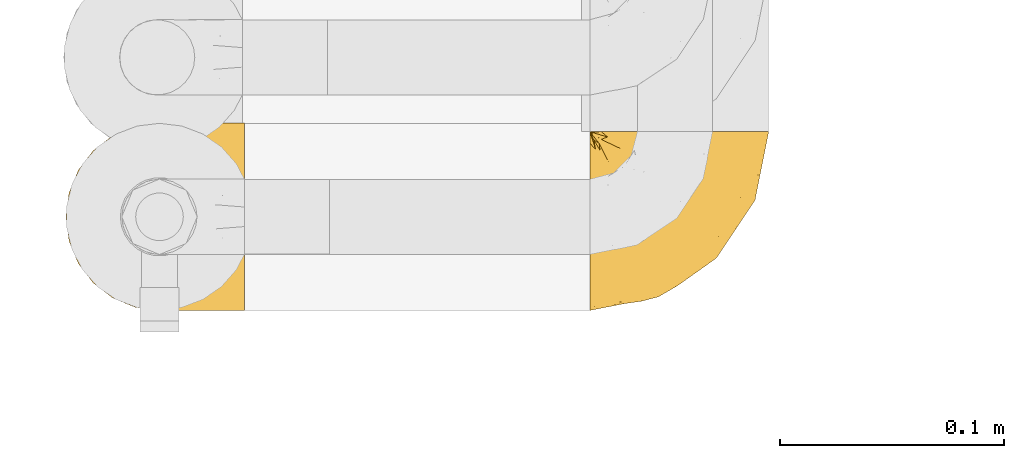
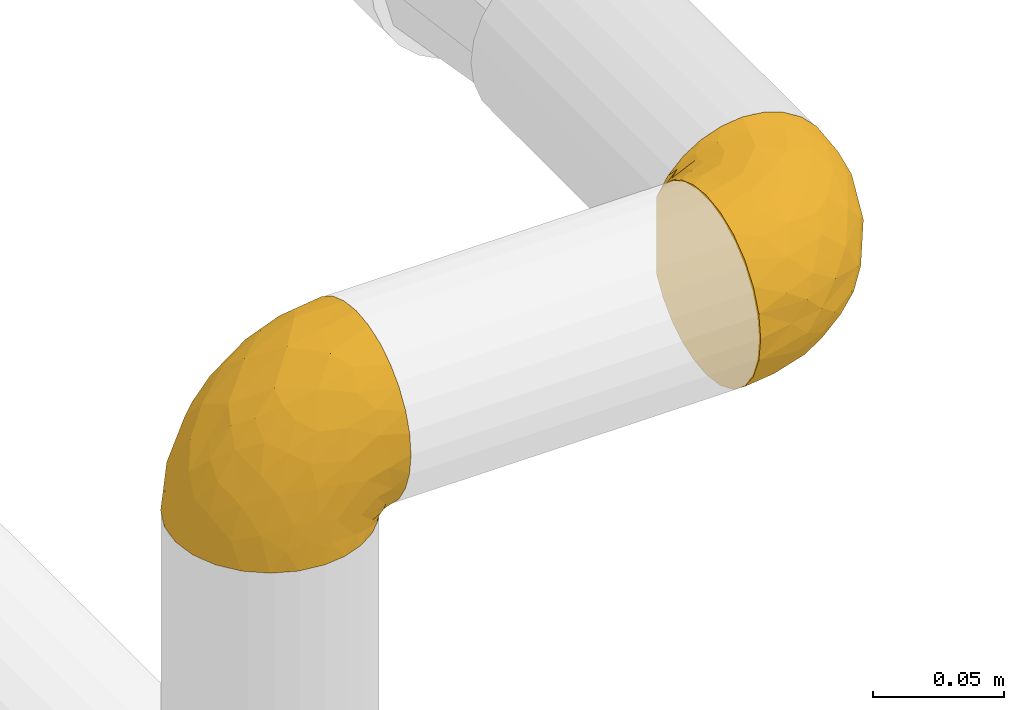
# One storey, part 123 of 827: 2 coverings.
"""IFC2X3 building model written with IfcOpenShell, lengths in millimetres."""

from ifc_helpers import new_model, entity, si_unit, converted_unit, derived_unit, direction, frame, origin, place, context, subcontext, project, spatial, faceted_brep, element, save


model = new_model("IFC2X3")

# Units and contexts
model_context = context("Model", 3, precision=0.01, world=origin(), true_north=direction((6.12303176911189e-17, 1.0)))
body_context = subcontext(model_context, "Body", "Model", "MODEL_VIEW")
ifc_project = project(units=[si_unit("LENGTHUNIT", "METRE", prefix="MILLI"), si_unit("AREAUNIT", "SQUARE_METRE"), si_unit("VOLUMEUNIT", "CUBIC_METRE"), converted_unit("PLANEANGLEUNIT", "DEGREE", entity("IfcRatioMeasure", 0.0174532925199433), si_unit("PLANEANGLEUNIT", "RADIAN"), dimensions=[0, 0, 0, 0, 0, 0, 0]), si_unit("MASSUNIT", "GRAM", prefix="KILO"), derived_unit("MASSDENSITYUNIT", [(si_unit("MASSUNIT", "GRAM", prefix="KILO"), 1), (si_unit("LENGTHUNIT", "METRE"), -3)]), derived_unit("MOMENTOFINERTIAUNIT", [(si_unit("LENGTHUNIT", "METRE"), 4)]), si_unit("TIMEUNIT", "SECOND"), si_unit("FREQUENCYUNIT", "HERTZ"), si_unit("THERMODYNAMICTEMPERATUREUNIT", "DEGREE_CELSIUS"), derived_unit("THERMALTRANSMITTANCEUNIT", [(si_unit("MASSUNIT", "GRAM", prefix="KILO"), 1), (si_unit("THERMODYNAMICTEMPERATUREUNIT", "KELVIN"), -1), (si_unit("TIMEUNIT", "SECOND"), -3)]), derived_unit("VOLUMETRICFLOWRATEUNIT", [(si_unit("LENGTHUNIT", "METRE"), 3), (si_unit("TIMEUNIT", "SECOND"), -1)]), derived_unit("MASSFLOWRATEUNIT", [(si_unit("MASSUNIT", "GRAM", prefix="KILO"), 1), (si_unit("TIMEUNIT", "SECOND"), -1)]), derived_unit("ROTATIONALFREQUENCYUNIT", [(si_unit("TIMEUNIT", "SECOND"), -1)]), si_unit("ELECTRICCURRENTUNIT", "AMPERE"), si_unit("ELECTRICVOLTAGEUNIT", "VOLT"), si_unit("POWERUNIT", "WATT"), si_unit("FORCEUNIT", "NEWTON", prefix="KILO"), si_unit("ILLUMINANCEUNIT", "LUX"), si_unit("LUMINOUSFLUXUNIT", "LUMEN"), si_unit("LUMINOUSINTENSITYUNIT", "CANDELA"), derived_unit("USERDEFINED", [(si_unit("MASSUNIT", "GRAM", prefix="KILO"), -1), (si_unit("LENGTHUNIT", "METRE"), -2), (si_unit("TIMEUNIT", "SECOND"), 3), (si_unit("LUMINOUSFLUXUNIT", "LUMEN"), 1)]), derived_unit("LINEARVELOCITYUNIT", [(si_unit("LENGTHUNIT", "METRE"), 1), (si_unit("TIMEUNIT", "SECOND"), -1)]), si_unit("PRESSUREUNIT", "PASCAL"), derived_unit("USERDEFINED", [(si_unit("LENGTHUNIT", "METRE"), -2), (si_unit("MASSUNIT", "GRAM", prefix="KILO"), 1), (si_unit("TIMEUNIT", "SECOND"), -2)]), derived_unit("LINEARFORCEUNIT", [(si_unit("MASSUNIT", "GRAM", prefix="KILO"), 1), (si_unit("LENGTHUNIT", "METRE"), 1), (si_unit("TIMEUNIT", "SECOND"), -2), (si_unit("LENGTHUNIT", "METRE"), -1)]), derived_unit("PLANARFORCEUNIT", [(si_unit("MASSUNIT", "GRAM", prefix="KILO"), 1), (si_unit("LENGTHUNIT", "METRE"), 1), (si_unit("TIMEUNIT", "SECOND"), -2), (si_unit("LENGTHUNIT", "METRE"), -2)])], contexts=[model_context])

# Site, building, storey
site_placement = place(None, origin())
site = spatial("IfcSite", under=ifc_project, at=site_placement, CompositionType="ELEMENT")
building_placement = place(site_placement, origin())
building = spatial("IfcBuilding", under=site, at=building_placement, CompositionType="ELEMENT")
storey_placement = place(building_placement, frame((0.0, 0.0, 28200.0)))
storey = spatial("IfcBuildingStorey", under=building, at=storey_placement, Name="08", CompositionType="ELEMENT", Elevation=28200.0)

# Coverings
covering_1_placement = place(storey_placement, frame((11731.77, 16451.2, 2230.69)))
element("IfcCovering", 1, at=covering_1_placement, inside=storey, Name=":ADSK_", ObjectType=":ADSK_", PredefinedType="INSULATION", context=body_context, shape_type="Brep", body=[
    faceted_brep([(81.45, 81.15, 57.76), (81.45, 76.16, 65.69), (81.45, 69.53, 72.32), (81.45, 61.6, 77.3), (81.45, 52.75, 80.4), (81.45, 43.45, 81.45), (81.45, 34.13, 80.39), (81.45, 25.28, 77.3), (81.45, 17.35, 72.31), (81.45, 10.72, 65.68), (81.45, 5.74, 57.75), (81.45, 2.64, 48.9), (81.45, 1.6, 39.6), (81.45, 2.66, 30.22), (81.45, 5.79, 21.33), (81.45, 10.83, 13.37), (81.45, 17.53, 6.73), (81.45, 25.53, 1.77), (81.45, 26.45, 1.77), (81.45, 27.37, 1.77), (81.45, 28.17, 1.77), (81.45, 29.49, 1.77), (81.45, 30.81, 1.77), (81.45, 32.13, 1.77), (81.45, 33.45, 1.77), (81.45, 34.78, 1.77), (81.45, 36.1, 1.77), (81.45, 37.42, 1.77), (81.45, 38.74, 1.77), (81.45, 40.06, 1.77), (81.45, 41.38, 1.77), (81.45, 42.7, 1.77), (81.45, 44.02, 1.77), (81.45, 45.34, 1.77), (81.45, 46.66, 1.77), (81.45, 47.58, 1.77), (81.45, 48.5, 1.77), (81.45, 49.41, 1.77), (81.45, 50.33, 1.77), (81.45, 51.25, 1.77), (81.45, 52.17, 1.77), (81.45, 53.09, 1.77), (81.45, 54.01, 1.77), (81.45, 54.93, 1.77), (81.45, 55.85, 1.77), (81.45, 56.76, 1.77), (81.45, 57.68, 1.77), (81.45, 58.6, 1.77), (81.45, 59.52, 1.77), (81.45, 60.44, 1.77), (81.45, 61.36, 1.77), (81.45, 69.37, 6.74), (81.45, 76.07, 13.38), (81.45, 81.11, 21.35), (81.45, 84.24, 30.24), (81.45, 85.3, 39.6), (81.45, 84.24, 48.91), (76.3, 17.52, 1.6), (69.67, 10.83, 1.6), (61.7, 5.79, 1.6), (52.81, 2.66, 1.6), (43.45, 1.6, 1.6), (32.61, 3.02, 1.6), (22.52, 7.2, 1.6), (13.85, 13.85, 1.6), (7.2, 22.52, 1.6), (3.02, 32.61, 1.6), (1.6, 43.45, 1.6), (3.02, 54.28, 1.6), (7.2, 64.37, 1.6), (13.85, 73.04, 1.6), (22.52, 79.69, 1.6), (32.61, 83.87, 1.6), (43.45, 85.3, 1.6), (52.81, 84.23, 1.6), (61.7, 81.1, 1.6), (69.67, 76.06, 1.6), (76.3, 69.37, 1.6), (81.27, 61.36, 1.6), (81.27, 60.44, 1.6), (81.27, 59.12, 1.6), (81.27, 58.0, 1.6), (81.27, 56.88, 1.6), (81.27, 55.76, 1.6), (81.27, 54.64, 1.6), (81.27, 53.52, 1.6), (81.27, 52.4, 1.6), (81.27, 51.28, 1.6), (81.27, 50.16, 1.6), (81.27, 49.04, 1.6), (81.27, 47.92, 1.6), (81.27, 46.8, 1.6), (81.27, 45.68, 1.6), (81.27, 44.56, 1.6), (81.27, 43.45, 1.6), (81.27, 42.12, 1.6), (81.27, 40.8, 1.6), (81.27, 39.48, 1.6), (81.27, 38.16, 1.6), (81.27, 36.84, 1.6), (81.27, 35.52, 1.6), (81.27, 34.2, 1.6), (81.27, 32.88, 1.6), (81.27, 31.96, 1.6), (81.27, 31.05, 1.6), (81.27, 30.13, 1.6), (81.27, 29.21, 1.6), (81.27, 28.29, 1.6), (81.27, 27.37, 1.6), (81.27, 26.45, 1.6), (81.27, 25.53, 1.6), (81.31, 54.08, 1.71), (81.33, 55.16, 1.73), (81.31, 36.18, 1.71), (81.32, 35.13, 1.72), (81.31, 44.01, 1.71), (81.32, 45.08, 1.72), (81.32, 61.36, 1.72), (81.32, 59.98, 1.72), (81.32, 46.18, 1.72), (81.32, 26.74, 1.72), (81.32, 47.36, 1.72), (81.32, 29.67, 1.72), (81.3, 28.72, 1.7), (81.32, 39.77, 1.72), (81.33, 52.96, 1.73), (81.31, 51.84, 1.72), (81.33, 40.8, 1.73), (81.32, 41.87, 1.73), (81.32, 42.94, 1.72), (81.32, 27.77, 1.72), (81.31, 48.4, 1.71), (81.32, 37.21, 1.72), (81.31, 33.54, 1.71), (81.32, 32.49, 1.72), (81.32, 30.69, 1.72), (81.32, 50.69, 1.72), (81.33, 49.6, 1.73), (81.32, 56.32, 1.72), (81.31, 57.44, 1.71), (81.33, 58.88, 1.73), (81.32, 25.53, 1.72), (81.36, 61.36, 1.74), (81.4, 61.36, 1.75), (81.4, 25.53, 1.75), (81.36, 25.53, 1.74), (81.29, 61.36, 1.64), (81.3, 61.36, 1.68), (81.3, 25.53, 1.68), (81.35, 31.59, 1.74), (81.31, 38.71, 1.71), (58.5, 3.97, 8.98), (71.95, 1.6, 37.05), (74.57, 3.97, 24.69), (73.93, 8.09, 15.28), (78.18, 8.09, 16.86), (78.04, 16.43, 6.58), (76.23, 15.73, 5.71), (45.99, 1.6, 11.1), (74.01, 10.79, 10.79), (73.57, 13.99, 4.13), (66.66, 8.08, 6.62), (79.09, 14.0, 9.52), (73.14, 12.83, 6.14), (81.29, 25.53, 1.64), (60.34, 3.18, 17.79), (48.54, 1.6, 20.6), (45.36, 1.6, 8.73), (67.22, 3.28, 23.66), (62.45, 1.6, 34.5), (68.67, 6.28, 15.32), (55.49, 1.6, 27.55), (77.84, 19.06, 3.31), (68.16, 8.08, 9.81), (74.31, 1.6, 37.68), (38.78, 32.11, 67.23), (62.1, 29.62, 76.64), (50.89, 43.45, 75.37), (36.91, 2.45, 14.58), (40.37, 2.5, 23.71), (27.86, 9.73, 34.34), (15.77, 17.97, 29.1), (20.13, 10.24, 18.02), (31.54, 4.78, 22.27), (28.25, 4.78, 10.97), (57.26, 8.01, 56.79), (69.99, 8.01, 60.76), (64.58, 13.85, 67.04), (50.64, 2.42, 36.11), (51.97, 21.17, 68.85), (5.72, 35.73, 24.58), (7.42, 27.43, 21.54), (66.14, 43.45, 78.4), (11.35, 17.97, 14.11), (21.64, 35.71, 53.42), (28.57, 29.47, 58.19), (55.38, 3.41, 44.49), (68.51, 3.94, 51.77), (67.48, 21.17, 73.69), (40.78, 7.92, 45.89), (41.53, 4.25, 35.97), (46.11, 11.75, 56.55), (40.32, 18.31, 60.03), (38.36, 24.94, 63.64), (11.84, 28.78, 34.98), (12.56, 35.82, 40.58), (7.67, 43.45, 32.15), (19.39, 28.38, 47.26), (24.98, 43.45, 58.06), (37.94, 43.45, 66.71), (4.64, 43.45, 16.9), (28.09, 21.21, 52.08), (23.73, 16.48, 41.21), (34.03, 13.85, 49.76), (16.33, 43.45, 45.11), (29.29, 82.11, 15.65), (5.77, 51.41, 24.57), (21.44, 57.45, 50.54), (38.8, 54.78, 67.25), (64.58, 73.03, 67.06), (67.49, 65.7, 73.7), (22.9, 76.65, 26.13), (12.54, 68.92, 19.54), (20.04, 68.01, 38.96), (57.26, 78.88, 56.8), (69.99, 78.88, 60.77), (68.51, 82.94, 51.78), (34.54, 64.44, 59.09), (38.81, 84.49, 19.25), (48.54, 85.3, 20.6), (45.99, 85.3, 11.1), (74.31, 85.3, 37.68), (5.36, 57.84, 15.21), (18.96, 76.65, 12.76), (12.79, 51.19, 40.93), (62.11, 57.26, 76.65), (33.14, 78.14, 39.5), (33.44, 82.35, 25.01), (51.98, 65.7, 68.86), (43.42, 84.61, 26.7), (48.62, 84.36, 34.95), (62.45, 85.3, 34.5), (55.49, 85.3, 27.55), (49.68, 73.03, 61.27), (55.37, 83.48, 44.5), (71.95, 85.3, 37.05), (36.37, 84.54, 10.25), (34.04, 73.03, 49.78), (44.1, 79.54, 47.51), (9.99, 59.46, 29.38), (26.41, 73.5, 40.01), (39.19, 82.57, 33.36), (58.5, 82.92, 8.98), (67.22, 83.62, 23.67), (74.57, 82.92, 24.71), (73.92, 78.81, 15.29), (73.57, 72.9, 4.13), (73.14, 74.06, 6.14), (66.19, 78.81, 4.96), (68.16, 78.81, 9.81), (77.84, 67.83, 3.31), (76.23, 71.15, 5.7), (79.08, 72.91, 9.53), (78.04, 70.47, 6.59), (77.18, 78.81, 16.63), (68.66, 80.62, 15.34), (74.0, 76.11, 10.8), (60.34, 83.71, 17.79)], [[[0, 1, 2, 3, 4, 5, 6, 7, 8, 9, 10, 11, 12, 13, 14, 15, 16, 17, 18, 19, 20, 21, 22, 23, 24, 25, 26, 27, 28, 29, 30, 31, 32, 33, 34, 35, 36, 37, 38, 39, 40, 41, 42, 43, 44, 45, 46, 47, 48, 49, 50, 51, 52, 53, 54, 55, 56]], [[57, 58, 59, 60, 61, 62, 63, 64, 65, 66, 67, 68, 69, 70, 71, 72, 73, 74, 75, 76, 77, 78, 79, 80, 81, 82, 83, 84, 85, 86, 87, 88, 89, 90, 91, 92, 93, 94, 95, 96, 97, 98, 99, 100, 101, 102, 103, 104, 105, 106, 107, 108, 109, 110]], [[111, 84, 112]], [[113, 26, 114]], [[114, 101, 100]], [[115, 93, 116]], [[79, 117, 118]], [[33, 116, 119]], [[117, 49, 118]], [[19, 18, 120]], [[119, 121, 34]], [[122, 21, 123]], [[97, 96, 124]], [[86, 125, 126]], [[116, 92, 119]], [[127, 96, 128]], [[32, 129, 115]], [[19, 120, 130]], [[121, 90, 131]], [[94, 115, 129]], [[115, 116, 32]], [[118, 49, 48]], [[113, 99, 132]], [[133, 114, 25]], [[24, 134, 133]], [[135, 22, 122]], [[136, 137, 88]], [[84, 83, 112]], [[138, 82, 139]], [[130, 20, 19]], [[118, 48, 140]], [[81, 140, 139]], [[123, 21, 20]], [[141, 120, 18]], [[139, 82, 81]], [[130, 107, 123]], [[49, 117, 142, 143, 50]], [[18, 17, 144, 145, 141]], [[79, 78, 146, 147, 117]], [[109, 141, 148]], [[102, 133, 134]], [[105, 135, 122]], [[118, 80, 79]], [[80, 118, 140]], [[120, 109, 108]], [[47, 46, 140, 48]], [[81, 80, 140]], [[44, 112, 138]], [[93, 115, 94]], [[46, 139, 140]], [[46, 45, 139]], [[139, 45, 138]], [[138, 112, 83]], [[85, 84, 111]], [[112, 43, 111]], [[83, 82, 138]], [[106, 122, 123]], [[105, 122, 106]], [[21, 122, 22]], [[124, 29, 28]], [[33, 32, 116]], [[128, 129, 31]], [[32, 31, 129]], [[34, 33, 119]], [[116, 93, 92]], [[129, 95, 94]], [[95, 129, 128]], [[41, 40, 125, 42]], [[119, 91, 121]], [[36, 35, 131, 37]], [[137, 131, 89]], [[121, 131, 35]], [[90, 121, 91]], [[119, 92, 91]], [[136, 126, 39]], [[125, 86, 85]], [[42, 125, 111]], [[85, 111, 125]], [[149, 23, 22]], [[130, 108, 107]], [[130, 123, 20]], [[107, 106, 123]], [[137, 37, 131]], [[136, 38, 137]], [[89, 88, 137]], [[131, 90, 89]], [[124, 150, 97]], [[40, 39, 126]], [[87, 126, 136]], [[86, 126, 87]], [[136, 88, 87]], [[40, 126, 125]], [[39, 38, 136]], [[95, 128, 96]], [[30, 128, 31]], [[29, 124, 127]], [[127, 128, 30]], [[150, 124, 28]], [[127, 30, 29]], [[127, 124, 96]], [[150, 98, 97]], [[45, 44, 138]], [[26, 113, 132]], [[113, 100, 99]], [[132, 150, 27]], [[27, 26, 132]], [[26, 25, 114]], [[100, 113, 114]], [[101, 133, 102]], [[133, 101, 114]], [[28, 27, 150]], [[132, 99, 98]], [[23, 134, 24]], [[25, 24, 133]], [[134, 23, 149]], [[135, 104, 149]], [[149, 104, 103]], [[103, 102, 134]], [[130, 120, 108]], [[109, 120, 141]], [[42, 111, 43]], [[112, 44, 43]], [[104, 135, 105]], [[134, 149, 103]], [[135, 149, 22]], [[35, 34, 121]], [[137, 38, 37]], [[98, 150, 132]], [[59, 151, 60]], [[13, 152, 153]], [[154, 155, 153]], [[156, 157, 141]], [[158, 60, 151]], [[159, 156, 154]], [[160, 161, 58]], [[58, 161, 59]], [[144, 16, 162]], [[58, 57, 160]], [[161, 160, 163]], [[156, 162, 154]], [[162, 16, 15]], [[57, 164, 160]], [[151, 165, 166]], [[156, 144, 162]], [[60, 158, 167, 61]], [[155, 14, 153]], [[162, 155, 154]], [[154, 153, 168]], [[168, 153, 169]], [[154, 170, 159]], [[57, 110, 164]], [[144, 17, 16]], [[155, 15, 14]], [[171, 165, 168]], [[157, 163, 172]], [[14, 13, 153]], [[156, 141, 145, 144]], [[173, 163, 157]], [[173, 159, 170]], [[171, 166, 165]], [[168, 165, 170]], [[168, 169, 171]], [[151, 173, 165]], [[170, 154, 168]], [[165, 173, 170]], [[159, 173, 157]], [[172, 164, 148]], [[148, 141, 157]], [[157, 156, 159]], [[151, 166, 158]], [[173, 151, 161]], [[59, 161, 151]], [[13, 12, 174, 152]], [[152, 169, 153]], [[15, 155, 162]], [[161, 163, 173]], [[172, 163, 160]], [[164, 172, 160]], [[157, 172, 148]], [[175, 176, 177]], [[178, 166, 179]], [[180, 181, 182]], [[183, 184, 178]], [[185, 186, 187]], [[171, 188, 179]], [[174, 12, 11]], [[189, 176, 175]], [[190, 66, 191]], [[176, 6, 192]], [[193, 65, 64]], [[63, 184, 182]], [[63, 182, 64]], [[65, 193, 191]], [[184, 63, 62]], [[175, 194, 195]], [[196, 169, 197]], [[174, 11, 197]], [[8, 7, 198]], [[187, 9, 8]], [[197, 169, 152, 174]], [[197, 11, 10]], [[186, 197, 10]], [[199, 180, 200]], [[197, 185, 196]], [[201, 189, 202]], [[201, 187, 189]], [[195, 203, 175]], [[191, 204, 190]], [[176, 7, 6]], [[177, 176, 192]], [[189, 198, 176]], [[65, 191, 66]], [[198, 187, 8]], [[205, 206, 190]], [[9, 186, 10]], [[181, 207, 204]], [[208, 175, 177, 209]], [[66, 190, 210]], [[211, 212, 213]], [[190, 204, 205]], [[180, 182, 183]], [[193, 182, 181]], [[62, 61, 167]], [[196, 185, 199]], [[196, 200, 188]], [[6, 5, 192]], [[176, 198, 7]], [[187, 198, 189]], [[187, 186, 9]], [[197, 186, 185]], [[200, 180, 183]], [[180, 213, 212]], [[179, 183, 178]], [[185, 201, 199]], [[210, 190, 206]], [[210, 67, 66]], [[205, 204, 207]], [[194, 205, 207]], [[194, 214, 205]], [[195, 194, 207]], [[208, 194, 175]], [[207, 211, 195]], [[202, 203, 211]], [[212, 207, 181]], [[202, 211, 213]], [[201, 202, 213]], [[189, 175, 203]], [[199, 201, 213]], [[187, 201, 185]], [[180, 199, 213]], [[196, 199, 200]], [[211, 203, 195]], [[189, 203, 202]], [[207, 212, 211]], [[180, 212, 181]], [[214, 194, 208]], [[214, 206, 205]], [[196, 188, 169]], [[181, 204, 191]], [[182, 193, 64]], [[191, 193, 181]], [[178, 62, 167]], [[182, 184, 183]], [[62, 178, 184]], [[178, 167, 158, 166]], [[171, 179, 166]], [[200, 183, 179]], [[179, 188, 200]], [[169, 188, 171]], [[71, 215, 72]], [[206, 216, 210]], [[217, 208, 218]], [[216, 68, 210]], [[219, 220, 2]], [[221, 222, 223]], [[224, 225, 226]], [[227, 223, 217]], [[228, 229, 230]], [[56, 231, 226]], [[232, 222, 69]], [[56, 55, 231]], [[70, 233, 71]], [[71, 233, 215]], [[0, 56, 226]], [[208, 217, 234]], [[218, 177, 235]], [[221, 236, 237]], [[238, 220, 219]], [[1, 219, 2]], [[68, 216, 232]], [[235, 3, 220]], [[235, 192, 4]], [[1, 0, 225]], [[228, 239, 229]], [[240, 241, 242]], [[243, 238, 219]], [[224, 226, 244]], [[226, 241, 244]], [[3, 235, 4]], [[69, 222, 70]], [[225, 219, 1]], [[218, 235, 238]], [[243, 219, 224]], [[218, 227, 217]], [[3, 2, 220]], [[218, 208, 209, 177]], [[226, 231, 245, 241]], [[215, 228, 246]], [[247, 248, 236]], [[248, 224, 244]], [[223, 222, 249]], [[233, 222, 221]], [[242, 239, 240]], [[248, 247, 243]], [[217, 223, 249]], [[250, 247, 236]], [[216, 234, 249]], [[218, 238, 227]], [[192, 235, 177]], [[192, 5, 4]], [[72, 246, 73]], [[235, 220, 238]], [[226, 225, 0]], [[219, 225, 224]], [[240, 248, 244]], [[239, 242, 229]], [[236, 248, 251]], [[68, 67, 210]], [[234, 216, 206]], [[216, 249, 232]], [[234, 206, 214, 208]], [[249, 234, 217]], [[222, 232, 249]], [[69, 68, 232]], [[246, 228, 230]], [[237, 228, 215]], [[243, 227, 238]], [[223, 227, 247]], [[73, 246, 230]], [[215, 246, 72]], [[248, 243, 224]], [[227, 243, 247]], [[237, 236, 251]], [[250, 221, 223]], [[222, 233, 70]], [[215, 233, 221]], [[221, 237, 215]], [[239, 237, 251]], [[237, 239, 228]], [[239, 251, 240]], [[248, 240, 251]], [[241, 240, 244]], [[221, 250, 236]], [[223, 247, 250]], [[74, 230, 252]], [[253, 254, 255]], [[146, 77, 256]], [[257, 258, 259]], [[260, 256, 257]], [[260, 261, 147]], [[75, 74, 252]], [[51, 143, 262]], [[263, 143, 142, 117]], [[256, 77, 76]], [[252, 258, 75]], [[253, 241, 254]], [[254, 245, 54]], [[258, 256, 76]], [[53, 52, 264]], [[255, 265, 253]], [[254, 264, 255]], [[255, 264, 262]], [[75, 258, 76]], [[265, 255, 266]], [[255, 262, 263]], [[51, 50, 143]], [[54, 245, 231, 55]], [[51, 262, 52]], [[253, 267, 242]], [[254, 54, 53]], [[266, 259, 265]], [[146, 78, 77]], [[263, 117, 261]], [[146, 256, 260]], [[257, 259, 261]], [[267, 253, 265]], [[229, 267, 252]], [[242, 267, 229]], [[242, 241, 253]], [[252, 267, 259]], [[255, 263, 266]], [[259, 267, 265]], [[261, 117, 147]], [[263, 261, 266]], [[259, 266, 261]], [[230, 74, 73]], [[230, 229, 252]], [[259, 258, 252]], [[254, 241, 245]], [[53, 264, 254]], [[52, 262, 264]], [[143, 263, 262]], [[258, 257, 256]], [[261, 260, 257]], [[146, 260, 147]], [[109, 148, 164]], [[109, 164, 110]]]),
])
covering_2_placement = place(storey_placement, frame((11965.87, 16451.2, 2226.84)))
element("IfcCovering", 2, at=covering_2_placement, inside=storey, Name=":ADSK_", ObjectType=":ADSK_", PredefinedType="INSULATION", context=body_context, shape_type="Brep", body=[
    faceted_brep([(57.76, 81.45, 81.15), (65.69, 81.45, 76.16), (72.32, 81.45, 69.53), (77.3, 81.45, 61.6), (80.4, 81.45, 52.75), (81.45, 81.45, 43.45), (80.39, 81.45, 34.13), (77.3, 81.45, 25.28), (72.31, 81.45, 17.35), (65.68, 81.45, 10.72), (57.75, 81.45, 5.74), (48.9, 81.45, 2.64), (39.6, 81.45, 1.6), (30.22, 81.45, 2.66), (21.33, 81.45, 5.79), (13.37, 81.45, 10.83), (6.73, 81.45, 17.53), (1.77, 81.45, 25.53), (1.77, 81.45, 26.45), (1.77, 81.45, 27.37), (1.77, 81.45, 28.17), (1.77, 81.45, 29.49), (1.77, 81.45, 30.81), (1.77, 81.45, 32.13), (1.77, 81.45, 33.45), (1.77, 81.45, 34.78), (1.77, 81.45, 36.1), (1.77, 81.45, 37.42), (1.77, 81.45, 38.74), (1.77, 81.45, 40.06), (1.77, 81.45, 41.38), (1.77, 81.45, 42.7), (1.77, 81.45, 44.02), (1.77, 81.45, 45.34), (1.77, 81.45, 46.66), (1.77, 81.45, 47.58), (1.77, 81.45, 48.5), (1.77, 81.45, 49.41), (1.77, 81.45, 50.33), (1.77, 81.45, 51.25), (1.77, 81.45, 52.17), (1.77, 81.45, 53.09), (1.77, 81.45, 54.01), (1.77, 81.45, 54.93), (1.77, 81.45, 55.85), (1.77, 81.45, 56.76), (1.77, 81.45, 57.68), (1.77, 81.45, 58.6), (1.77, 81.45, 59.52), (1.77, 81.45, 60.44), (1.77, 81.45, 61.36), (6.74, 81.45, 69.37), (13.38, 81.45, 76.07), (21.35, 81.45, 81.11), (30.24, 81.45, 84.24), (39.6, 81.45, 85.3), (48.91, 81.45, 84.24), (1.6, 76.3, 17.52), (1.6, 69.67, 10.83), (1.6, 61.7, 5.79), (1.6, 52.81, 2.66), (1.6, 43.45, 1.6), (1.6, 32.61, 3.02), (1.6, 22.52, 7.2), (1.6, 13.85, 13.85), (1.6, 7.2, 22.52), (1.6, 3.02, 32.61), (1.6, 1.6, 43.45), (1.6, 3.02, 54.28), (1.6, 7.2, 64.37), (1.6, 13.85, 73.04), (1.6, 22.52, 79.69), (1.6, 32.61, 83.87), (1.6, 43.45, 85.3), (1.6, 52.81, 84.23), (1.6, 61.7, 81.1), (1.6, 69.67, 76.06), (1.6, 76.3, 69.37), (1.6, 81.27, 61.36), (1.6, 81.27, 60.44), (1.6, 81.27, 59.12), (1.6, 81.27, 58.0), (1.6, 81.27, 56.88), (1.6, 81.27, 55.76), (1.6, 81.27, 54.64), (1.6, 81.27, 53.52), (1.6, 81.27, 52.4), (1.6, 81.27, 51.28), (1.6, 81.27, 50.16), (1.6, 81.27, 49.04), (1.6, 81.27, 47.92), (1.6, 81.27, 46.8), (1.6, 81.27, 45.68), (1.6, 81.27, 44.56), (1.6, 81.27, 43.45), (1.6, 81.27, 42.12), (1.6, 81.27, 40.8), (1.6, 81.27, 39.48), (1.6, 81.27, 38.16), (1.6, 81.27, 36.84), (1.6, 81.27, 35.52), (1.6, 81.27, 34.2), (1.6, 81.27, 32.88), (1.6, 81.27, 31.96), (1.6, 81.27, 31.05), (1.6, 81.27, 30.13), (1.6, 81.27, 29.21), (1.6, 81.27, 28.29), (1.6, 81.27, 27.37), (1.6, 81.27, 26.45), (1.6, 81.27, 25.53), (1.71, 81.31, 54.08), (1.73, 81.33, 55.16), (1.71, 81.31, 36.18), (1.72, 81.32, 35.13), (1.71, 81.31, 44.01), (1.72, 81.32, 45.08), (1.72, 81.32, 61.36), (1.72, 81.32, 59.98), (1.72, 81.32, 46.18), (1.72, 81.32, 26.74), (1.72, 81.32, 47.36), (1.72, 81.32, 29.67), (1.7, 81.3, 28.72), (1.72, 81.32, 39.77), (1.73, 81.33, 52.96), (1.72, 81.31, 51.84), (1.73, 81.33, 40.8), (1.73, 81.32, 41.87), (1.72, 81.32, 42.94), (1.72, 81.32, 27.77), (1.71, 81.31, 48.4), (1.72, 81.32, 37.21), (1.71, 81.31, 33.54), (1.72, 81.32, 32.49), (1.72, 81.32, 30.69), (1.72, 81.32, 50.69), (1.73, 81.33, 49.6), (1.72, 81.32, 56.32), (1.71, 81.31, 57.44), (1.73, 81.33, 58.88), (1.72, 81.32, 25.53), (1.74, 81.36, 61.36), (1.75, 81.4, 61.36), (1.75, 81.4, 25.53), (1.74, 81.36, 25.53), (1.64, 81.29, 61.36), (1.68, 81.3, 61.36), (1.68, 81.3, 25.53), (1.64, 81.29, 25.53), (1.74, 81.35, 31.59), (1.71, 81.31, 38.71), (8.98, 58.5, 3.97), (37.05, 71.95, 1.6), (24.69, 74.57, 3.97), (15.28, 73.93, 8.09), (16.86, 78.18, 8.09), (6.58, 78.04, 16.43), (5.71, 76.23, 15.73), (11.1, 45.99, 1.6), (10.79, 74.01, 10.79), (4.13, 73.57, 13.99), (6.62, 66.66, 8.08), (9.52, 79.09, 14.0), (6.14, 73.14, 12.83), (17.79, 60.34, 3.18), (20.6, 48.54, 1.6), (8.73, 45.36, 1.6), (23.66, 67.22, 3.28), (34.5, 62.45, 1.6), (15.32, 68.67, 6.28), (27.55, 55.49, 1.6), (3.31, 77.84, 19.06), (9.81, 68.16, 8.08), (37.68, 74.31, 1.6), (67.23, 38.78, 32.11), (76.64, 62.1, 29.62), (75.37, 50.89, 43.45), (14.58, 36.91, 2.45), (23.71, 40.37, 2.5), (34.34, 27.86, 9.73), (29.1, 15.77, 17.97), (18.02, 20.13, 10.24), (22.27, 31.54, 4.78), (10.97, 28.25, 4.78), (56.79, 57.26, 8.01), (60.76, 69.99, 8.01), (67.04, 64.58, 13.85), (36.11, 50.64, 2.42), (68.85, 51.97, 21.17), (24.58, 5.72, 35.73), (21.54, 7.42, 27.43), (78.4, 66.14, 43.45), (14.11, 11.35, 17.97), (53.42, 21.64, 35.71), (58.19, 28.57, 29.47), (44.49, 55.38, 3.41), (51.77, 68.51, 3.94), (73.69, 67.48, 21.17), (45.89, 40.78, 7.92), (35.97, 41.53, 4.25), (56.55, 46.11, 11.75), (60.03, 40.32, 18.31), (63.64, 38.36, 24.94), (34.98, 11.84, 28.78), (40.58, 12.56, 35.82), (32.15, 7.67, 43.45), (47.26, 19.39, 28.38), (58.06, 24.98, 43.45), (66.71, 37.94, 43.45), (16.9, 4.64, 43.45), (52.08, 28.09, 21.21), (41.21, 23.73, 16.48), (49.76, 34.03, 13.85), (45.11, 16.33, 43.45), (15.65, 29.29, 82.11), (24.57, 5.77, 51.41), (50.54, 21.44, 57.45), (67.25, 38.8, 54.78), (67.06, 64.58, 73.03), (73.7, 67.49, 65.7), (26.13, 22.9, 76.65), (19.54, 12.54, 68.92), (38.96, 20.04, 68.01), (56.8, 57.26, 78.88), (60.77, 69.99, 78.88), (51.78, 68.51, 82.94), (59.09, 34.54, 64.44), (19.25, 38.81, 84.49), (20.6, 48.54, 85.3), (11.1, 45.99, 85.3), (37.68, 74.31, 85.3), (15.21, 5.36, 57.84), (12.76, 18.96, 76.65), (40.93, 12.79, 51.19), (76.65, 62.11, 57.26), (39.5, 33.14, 78.14), (25.01, 33.44, 82.35), (68.86, 51.98, 65.7), (26.7, 43.42, 84.61), (34.95, 48.62, 84.36), (34.5, 62.45, 85.3), (27.55, 55.49, 85.3), (61.27, 49.68, 73.03), (44.5, 55.37, 83.48), (37.05, 71.95, 85.3), (10.25, 36.37, 84.54), (49.78, 34.04, 73.03), (47.51, 44.1, 79.54), (29.38, 9.99, 59.46), (40.01, 26.41, 73.5), (33.36, 39.19, 82.57), (8.98, 58.5, 82.92), (23.67, 67.22, 83.62), (24.71, 74.57, 82.92), (15.29, 73.92, 78.81), (4.13, 73.57, 72.9), (6.14, 73.14, 74.06), (4.96, 66.19, 78.81), (9.81, 68.16, 78.81), (3.31, 77.84, 67.83), (5.7, 76.23, 71.15), (9.53, 79.08, 72.91), (6.59, 78.04, 70.47), (16.63, 77.18, 78.81), (15.34, 68.66, 80.62), (10.8, 74.0, 76.11), (17.79, 60.34, 83.71)], [[[0, 1, 2, 3, 4, 5, 6, 7, 8, 9, 10, 11, 12, 13, 14, 15, 16, 17, 18, 19, 20, 21, 22, 23, 24, 25, 26, 27, 28, 29, 30, 31, 32, 33, 34, 35, 36, 37, 38, 39, 40, 41, 42, 43, 44, 45, 46, 47, 48, 49, 50, 51, 52, 53, 54, 55, 56]], [[57, 58, 59, 60, 61, 62, 63, 64, 65, 66, 67, 68, 69, 70, 71, 72, 73, 74, 75, 76, 77, 78, 79, 80, 81, 82, 83, 84, 85, 86, 87, 88, 89, 90, 91, 92, 93, 94, 95, 96, 97, 98, 99, 100, 101, 102, 103, 104, 105, 106, 107, 108, 109, 110]], [[111, 84, 112]], [[113, 26, 114]], [[114, 101, 100]], [[115, 93, 116]], [[79, 117, 118]], [[33, 116, 119]], [[117, 49, 118]], [[19, 18, 120]], [[119, 121, 34]], [[122, 21, 123]], [[97, 96, 124]], [[86, 125, 126]], [[116, 92, 119]], [[127, 96, 128]], [[32, 129, 115]], [[19, 120, 130]], [[121, 90, 131]], [[94, 115, 129]], [[115, 116, 32]], [[118, 49, 48]], [[113, 99, 132]], [[133, 114, 25]], [[24, 134, 133]], [[135, 22, 122]], [[136, 137, 88]], [[84, 83, 112]], [[138, 82, 139]], [[130, 20, 19]], [[118, 48, 140]], [[81, 140, 139]], [[123, 21, 20]], [[141, 120, 18]], [[139, 82, 81]], [[130, 107, 123]], [[49, 117, 142, 143, 50]], [[18, 17, 144, 145, 141]], [[79, 78, 146, 147, 117]], [[109, 141, 148, 149, 110]], [[102, 133, 134]], [[105, 135, 122]], [[118, 80, 79]], [[80, 118, 140]], [[120, 109, 108]], [[47, 46, 140, 48]], [[81, 80, 140]], [[44, 112, 138]], [[93, 115, 94]], [[46, 139, 140]], [[46, 45, 139]], [[139, 45, 138]], [[138, 112, 83]], [[85, 84, 111]], [[112, 43, 111]], [[83, 82, 138]], [[106, 122, 123]], [[105, 122, 106]], [[21, 122, 22]], [[124, 29, 28]], [[33, 32, 116]], [[128, 129, 31]], [[32, 31, 129]], [[34, 33, 119]], [[116, 93, 92]], [[129, 95, 94]], [[95, 129, 128]], [[41, 40, 125, 42]], [[119, 91, 121]], [[36, 35, 131, 37]], [[137, 131, 89]], [[121, 131, 35]], [[90, 121, 91]], [[119, 92, 91]], [[136, 126, 39]], [[125, 86, 85]], [[42, 125, 111]], [[85, 111, 125]], [[150, 23, 22]], [[130, 108, 107]], [[130, 123, 20]], [[107, 106, 123]], [[137, 37, 131]], [[136, 38, 137]], [[89, 88, 137]], [[131, 90, 89]], [[124, 151, 97]], [[40, 39, 126]], [[87, 126, 136]], [[86, 126, 87]], [[136, 88, 87]], [[40, 126, 125]], [[39, 38, 136]], [[95, 128, 96]], [[30, 128, 31]], [[29, 124, 127]], [[127, 128, 30]], [[151, 124, 28]], [[127, 30, 29]], [[127, 124, 96]], [[151, 98, 97]], [[45, 44, 138]], [[26, 113, 132]], [[113, 100, 99]], [[132, 151, 27]], [[27, 26, 132]], [[26, 25, 114]], [[100, 113, 114]], [[101, 133, 102]], [[133, 101, 114]], [[28, 27, 151]], [[132, 99, 98]], [[23, 134, 24]], [[25, 24, 133]], [[134, 23, 150]], [[135, 104, 150]], [[150, 104, 103]], [[103, 102, 134]], [[130, 120, 108]], [[109, 120, 141]], [[42, 111, 43]], [[112, 44, 43]], [[104, 135, 105]], [[134, 150, 103]], [[135, 150, 22]], [[35, 34, 121]], [[137, 38, 37]], [[98, 151, 132]], [[59, 152, 60]], [[13, 153, 154]], [[155, 156, 154]], [[157, 158, 141]], [[159, 60, 152]], [[160, 157, 155]], [[161, 162, 58]], [[58, 162, 59]], [[144, 16, 163]], [[58, 57, 161]], [[162, 161, 164]], [[157, 163, 155]], [[163, 16, 15]], [[57, 149, 161]], [[152, 165, 166]], [[157, 144, 163]], [[60, 159, 167, 61]], [[156, 14, 154]], [[163, 156, 155]], [[155, 154, 168]], [[168, 154, 169]], [[155, 170, 160]], [[57, 110, 149]], [[144, 17, 16]], [[156, 15, 14]], [[171, 165, 168]], [[158, 164, 172]], [[14, 13, 154]], [[157, 141, 145, 144]], [[173, 164, 158]], [[173, 160, 170]], [[171, 166, 165]], [[168, 165, 170]], [[168, 169, 171]], [[152, 173, 165]], [[170, 155, 168]], [[165, 173, 170]], [[160, 173, 158]], [[172, 149, 148]], [[148, 141, 158]], [[158, 157, 160]], [[152, 166, 159]], [[173, 152, 162]], [[59, 162, 152]], [[13, 12, 174, 153]], [[153, 169, 154]], [[15, 156, 163]], [[162, 164, 173]], [[172, 164, 161]], [[149, 172, 161]], [[158, 172, 148]], [[175, 176, 177]], [[178, 166, 179]], [[180, 181, 182]], [[183, 184, 178]], [[185, 186, 187]], [[171, 188, 179]], [[174, 12, 11]], [[189, 176, 175]], [[190, 66, 191]], [[176, 6, 192]], [[193, 65, 64]], [[63, 184, 182]], [[63, 182, 64]], [[65, 193, 191]], [[184, 63, 62]], [[175, 194, 195]], [[196, 169, 197]], [[174, 11, 197]], [[8, 7, 198]], [[187, 9, 8]], [[197, 169, 153, 174]], [[197, 11, 10]], [[186, 197, 10]], [[199, 180, 200]], [[197, 185, 196]], [[201, 189, 202]], [[201, 187, 189]], [[195, 203, 175]], [[191, 204, 190]], [[176, 7, 6]], [[177, 176, 192]], [[189, 198, 176]], [[65, 191, 66]], [[198, 187, 8]], [[205, 206, 190]], [[9, 186, 10]], [[181, 207, 204]], [[208, 175, 177, 209]], [[66, 190, 210]], [[211, 212, 213]], [[190, 204, 205]], [[180, 182, 183]], [[193, 182, 181]], [[62, 61, 167]], [[196, 185, 199]], [[196, 200, 188]], [[6, 5, 192]], [[176, 198, 7]], [[187, 198, 189]], [[187, 186, 9]], [[197, 186, 185]], [[200, 180, 183]], [[180, 213, 212]], [[179, 183, 178]], [[185, 201, 199]], [[210, 190, 206]], [[210, 67, 66]], [[205, 204, 207]], [[194, 205, 207]], [[194, 214, 205]], [[195, 194, 207]], [[208, 194, 175]], [[207, 211, 195]], [[202, 203, 211]], [[212, 207, 181]], [[202, 211, 213]], [[201, 202, 213]], [[189, 175, 203]], [[199, 201, 213]], [[187, 201, 185]], [[180, 199, 213]], [[196, 199, 200]], [[211, 203, 195]], [[189, 203, 202]], [[207, 212, 211]], [[180, 212, 181]], [[214, 194, 208]], [[214, 206, 205]], [[196, 188, 169]], [[181, 204, 191]], [[182, 193, 64]], [[191, 193, 181]], [[178, 62, 167]], [[182, 184, 183]], [[62, 178, 184]], [[178, 167, 159, 166]], [[171, 179, 166]], [[200, 183, 179]], [[179, 188, 200]], [[169, 188, 171]], [[71, 215, 72]], [[206, 216, 210]], [[217, 208, 218]], [[216, 68, 210]], [[219, 220, 2]], [[221, 222, 223]], [[224, 225, 226]], [[227, 223, 217]], [[228, 229, 230]], [[56, 231, 226]], [[232, 222, 69]], [[56, 55, 231]], [[70, 233, 71]], [[71, 233, 215]], [[0, 56, 226]], [[208, 217, 234]], [[218, 177, 235]], [[221, 236, 237]], [[238, 220, 219]], [[1, 219, 2]], [[68, 216, 232]], [[235, 3, 220]], [[235, 192, 4]], [[1, 0, 225]], [[228, 239, 229]], [[240, 241, 242]], [[243, 238, 219]], [[224, 226, 244]], [[226, 241, 244]], [[3, 235, 4]], [[69, 222, 70]], [[225, 219, 1]], [[218, 235, 238]], [[243, 219, 224]], [[218, 227, 217]], [[3, 2, 220]], [[218, 208, 209, 177]], [[226, 231, 245, 241]], [[215, 228, 246]], [[247, 248, 236]], [[248, 224, 244]], [[223, 222, 249]], [[233, 222, 221]], [[242, 239, 240]], [[248, 247, 243]], [[217, 223, 249]], [[250, 247, 236]], [[216, 234, 249]], [[218, 238, 227]], [[192, 235, 177]], [[192, 5, 4]], [[72, 246, 73]], [[235, 220, 238]], [[226, 225, 0]], [[219, 225, 224]], [[240, 248, 244]], [[239, 242, 229]], [[236, 248, 251]], [[68, 67, 210]], [[234, 216, 206]], [[216, 249, 232]], [[234, 206, 214, 208]], [[249, 234, 217]], [[222, 232, 249]], [[69, 68, 232]], [[246, 228, 230]], [[237, 228, 215]], [[243, 227, 238]], [[223, 227, 247]], [[73, 246, 230]], [[215, 246, 72]], [[248, 243, 224]], [[227, 243, 247]], [[237, 236, 251]], [[250, 221, 223]], [[222, 233, 70]], [[215, 233, 221]], [[221, 237, 215]], [[239, 237, 251]], [[237, 239, 228]], [[239, 251, 240]], [[248, 240, 251]], [[241, 240, 244]], [[221, 250, 236]], [[223, 247, 250]], [[74, 230, 252]], [[253, 254, 255]], [[146, 77, 256]], [[257, 258, 259]], [[260, 256, 257]], [[260, 261, 147]], [[75, 74, 252]], [[51, 143, 262]], [[263, 143, 142, 117]], [[256, 77, 76]], [[252, 258, 75]], [[253, 241, 254]], [[254, 245, 54]], [[258, 256, 76]], [[53, 52, 264]], [[255, 265, 253]], [[254, 264, 255]], [[255, 264, 262]], [[75, 258, 76]], [[265, 255, 266]], [[255, 262, 263]], [[51, 50, 143]], [[54, 245, 231, 55]], [[51, 262, 52]], [[253, 267, 242]], [[254, 54, 53]], [[266, 259, 265]], [[146, 78, 77]], [[263, 117, 261]], [[146, 256, 260]], [[257, 259, 261]], [[267, 253, 265]], [[229, 267, 252]], [[242, 267, 229]], [[242, 241, 253]], [[252, 267, 259]], [[255, 263, 266]], [[259, 267, 265]], [[261, 117, 147]], [[263, 261, 266]], [[259, 266, 261]], [[230, 74, 73]], [[230, 229, 252]], [[259, 258, 252]], [[254, 241, 245]], [[53, 264, 254]], [[52, 262, 264]], [[143, 263, 262]], [[258, 257, 256]], [[261, 260, 257]], [[146, 260, 147]]]),
])

save(model, "model.ifc")
